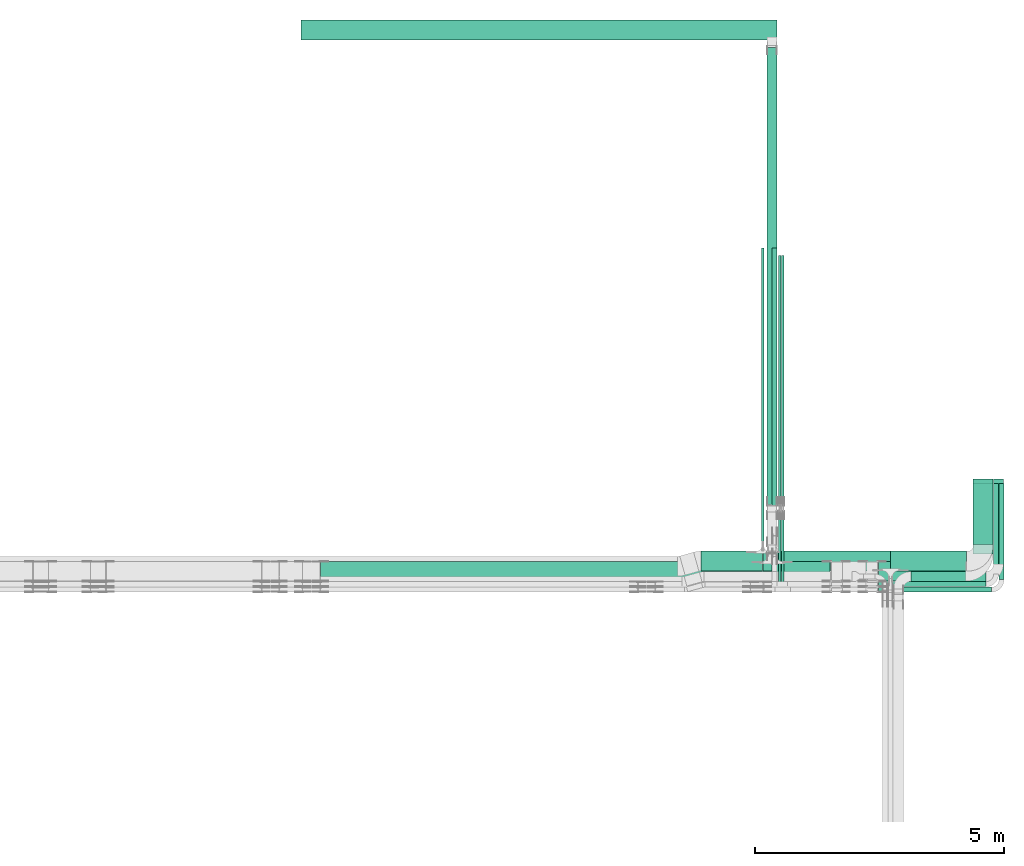
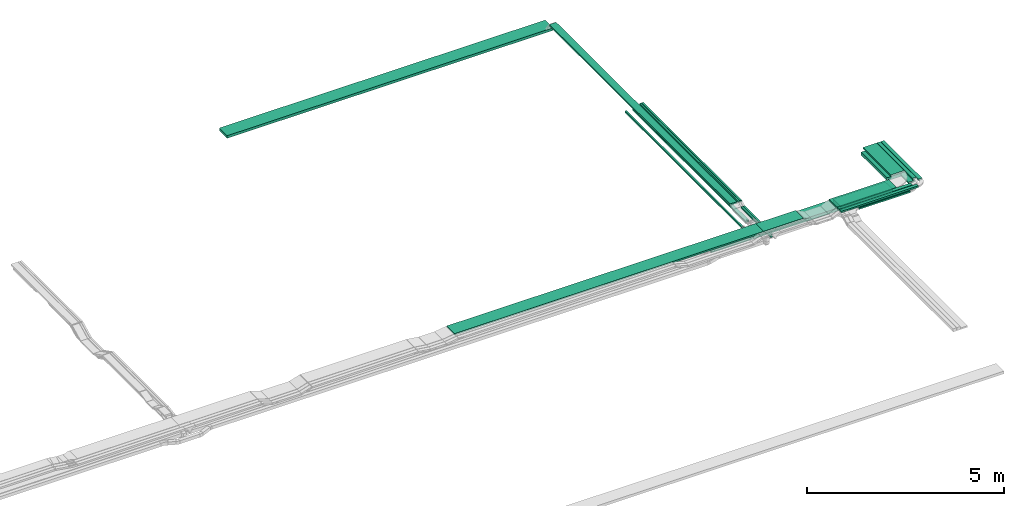
# One storey, part 3 of 28: 22 flow segments.
"""IFC2X3 building model written with IfcOpenShell, lengths in millimetres."""

from ifc_helpers import new_model, entity, si_unit, converted_unit, derived_unit, direction, frame, frame_2d, origin, origin_2d_with_axis, place, context, subcontext, project, spatial, rectangle, extrude, type_object, element, save


model = new_model("IFC2X3")

# Units and contexts
model_context = context("Model", 3, precision=0.01, world=origin(), true_north=direction((6.12303176911189e-17, 1.0)))
body_context = subcontext(model_context, "Body", "Model", "MODEL_VIEW")
ifc_project = project(units=[si_unit("LENGTHUNIT", "METRE", prefix="MILLI"), si_unit("AREAUNIT", "SQUARE_METRE"), si_unit("VOLUMEUNIT", "CUBIC_METRE"), converted_unit("PLANEANGLEUNIT", "DEGREE", entity("IfcRatioMeasure", 0.0174532925199433), si_unit("PLANEANGLEUNIT", "RADIAN"), dimensions=[0, 0, 0, 0, 0, 0, 0]), si_unit("MASSUNIT", "GRAM", prefix="KILO"), derived_unit("MASSDENSITYUNIT", [(si_unit("MASSUNIT", "GRAM", prefix="KILO"), 1), (si_unit("LENGTHUNIT", "METRE"), -3)]), derived_unit("MOMENTOFINERTIAUNIT", [(si_unit("LENGTHUNIT", "METRE"), 4)]), si_unit("TIMEUNIT", "SECOND"), si_unit("FREQUENCYUNIT", "HERTZ"), si_unit("THERMODYNAMICTEMPERATUREUNIT", "DEGREE_CELSIUS"), derived_unit("THERMALTRANSMITTANCEUNIT", [(si_unit("MASSUNIT", "GRAM", prefix="KILO"), 1), (si_unit("THERMODYNAMICTEMPERATUREUNIT", "KELVIN"), -1), (si_unit("TIMEUNIT", "SECOND"), -3)]), derived_unit("VOLUMETRICFLOWRATEUNIT", [(si_unit("LENGTHUNIT", "METRE"), 3), (si_unit("TIMEUNIT", "SECOND"), -1)]), derived_unit("MASSFLOWRATEUNIT", [(si_unit("MASSUNIT", "GRAM", prefix="KILO"), 1), (si_unit("TIMEUNIT", "SECOND"), -1)]), derived_unit("ROTATIONALFREQUENCYUNIT", [(si_unit("TIMEUNIT", "SECOND"), -1)]), si_unit("ELECTRICCURRENTUNIT", "AMPERE"), si_unit("ELECTRICVOLTAGEUNIT", "VOLT"), si_unit("POWERUNIT", "WATT"), si_unit("FORCEUNIT", "NEWTON", prefix="KILO"), si_unit("ILLUMINANCEUNIT", "LUX"), si_unit("LUMINOUSFLUXUNIT", "LUMEN"), si_unit("LUMINOUSINTENSITYUNIT", "CANDELA"), derived_unit("USERDEFINED", [(si_unit("MASSUNIT", "GRAM", prefix="KILO"), -1), (si_unit("LENGTHUNIT", "METRE"), -2), (si_unit("TIMEUNIT", "SECOND"), 3), (si_unit("LUMINOUSFLUXUNIT", "LUMEN"), 1)]), derived_unit("LINEARVELOCITYUNIT", [(si_unit("LENGTHUNIT", "METRE"), 1), (si_unit("TIMEUNIT", "SECOND"), -1)]), si_unit("PRESSUREUNIT", "PASCAL"), derived_unit("USERDEFINED", [(si_unit("LENGTHUNIT", "METRE"), -2), (si_unit("MASSUNIT", "GRAM", prefix="KILO"), 1), (si_unit("TIMEUNIT", "SECOND"), -2)]), derived_unit("LINEARFORCEUNIT", [(si_unit("MASSUNIT", "GRAM", prefix="KILO"), 1), (si_unit("LENGTHUNIT", "METRE"), 1), (si_unit("TIMEUNIT", "SECOND"), -2), (si_unit("LENGTHUNIT", "METRE"), -1)]), derived_unit("PLANARFORCEUNIT", [(si_unit("MASSUNIT", "GRAM", prefix="KILO"), 1), (si_unit("LENGTHUNIT", "METRE"), 1), (si_unit("TIMEUNIT", "SECOND"), -2), (si_unit("LENGTHUNIT", "METRE"), -2)])], contexts=[model_context])

# Site, building, storey
site_placement = place(None, frame((0.0, -0.00077364408347762, 0.0)))
site = spatial("IfcSite", under=ifc_project, at=site_placement, CompositionType="ELEMENT")
building_placement = place(site_placement, origin())
building = spatial("IfcBuilding", under=site, at=building_placement, CompositionType="ELEMENT")
storey_placement = place(building_placement, origin())
storey = spatial("IfcBuildingStorey", under=building, at=storey_placement, CompositionType="ELEMENT", Elevation=0.0)

# Flow segments
cable_carrier_segment_type = type_object("IfcCableCarrierSegmentType", PredefinedType="CABLETRAYSEGMENT")
flow_segment_1_placement = place(storey_placement, frame((64007.7697248974, 9444.27066099216, 2600.0)))
element("IfcFlowSegment", 1, at=flow_segment_1_placement, inside=storey, type_object=cable_carrier_segment_type, context=body_context, shape_type="SweptSolid", body=[
    extrude(rectangle(XDim=5768.12467532729, YDim=99.9999999999946, at=frame_2d((6.82121026329696e-13, 4.33075797445781e-12), x_axis=(1.0, 0.0))), frame((50.0, 2884.06233766365, 0.0), z_axis=(0.0, 0.0, 1.0), x_axis=(0.0, 1.0, 0.0)), (0.0, 0.0, 1.0), 49.9999999999995),
])
flow_segment_2_placement = place(storey_placement, frame((64197.1849606245, 10059.6497942623, 2800.0)))
element("IfcFlowSegment", 2, at=flow_segment_2_placement, inside=storey, type_object=cable_carrier_segment_type, context=body_context, shape_type="SweptSolid", body=[
    extrude(rectangle(XDim=5010.35026677283, YDim=50.000000000006, at=origin_2d_with_axis()), frame((25.0, 2505.17513338642, 0.0), z_axis=(0.0, 0.0, 1.0), x_axis=(0.0, 1.0, 0.0)), (0.0, 0.0, 1.0), 50.0000000000005),
])
flow_segment_3_placement = place(storey_placement, frame((64137.1849606246, 10059.6497942633, 2800.0)))
element("IfcFlowSegment", 3, at=flow_segment_3_placement, inside=storey, type_object=cable_carrier_segment_type, context=body_context, shape_type="SweptSolid", body=[
    extrude(rectangle(XDim=5010.3502667718, YDim=50.000000000006, at=frame_2d((-1.13686837721616e-12, 0.0), x_axis=(1.0, 0.0))), frame((25.0, 2505.1751333859, 0.0), z_axis=(0.0, 0.0, 1.0), x_axis=(0.0, 1.0, 0.0)), (0.0, 0.0, 1.0), 50.0000000000005),
])
flow_segment_4_placement = place(storey_placement, frame((63792.1849606245, 9272.39533631945, 2600.0)))
element("IfcFlowSegment", 4, at=flow_segment_4_placement, inside=storey, type_object=cable_carrier_segment_type, context=body_context, shape_type="SweptSolid", body=[
    extrude(rectangle(XDim=5940.0, YDim=50.000000000006, at=frame_2d((-1.13686837721616e-12, 0.0), x_axis=(1.0, 0.0))), frame((25.0, 2970.0, 0.0), z_axis=(0.0, 0.0, 1.0), x_axis=(0.0, -1.0, 0.0)), (0.0, 0.0, 1.0), 49.9999999999995),
])
flow_segment_5_placement = place(storey_placement, frame((68046.0094990459, 9254.3275570197, 2600.0)))
element("IfcFlowSegment", 5, at=flow_segment_5_placement, inside=storey, type_object=cable_carrier_segment_type, context=body_context, shape_type="SweptSolid", body=[
    extrude(rectangle(XDim=1317.94944193116, YDim=399.999999999996, at=frame_2d((1.08002495835535e-12, 0.0), x_axis=(1.0, 0.0))), frame((200.0, 658.974720965585, 0.0), z_axis=(0.0, 0.0, 1.0), x_axis=(0.0, -1.0, 0.0)), (0.0, 0.0, 1.0), 100.000000000001),
])
flow_segment_6_placement = place(storey_placement, frame((62577.106387771, 8724.32755701977, 2600.0)))
element("IfcFlowSegment", 6, at=flow_segment_6_placement, inside=storey, type_object=cable_carrier_segment_type, context=body_context, shape_type="SweptSolid", body=[
    extrude(rectangle(XDim=1239.07857285351, YDim=400.0, at=frame_2d((4.32009983342141e-12, 0.0), x_axis=(1.0, 0.0))), frame((619.539286426752, 200.0, 0.0)), (0.0, 0.0, 1.0), 100.0),
])
flow_segment_7_placement = place(storey_placement, frame((66385.9973266601, 8724.32755701969, 2600.0)))
element("IfcFlowSegment", 7, at=flow_segment_7_placement, inside=storey, type_object=cable_carrier_segment_type, context=body_context, shape_type="SweptSolid", body=[
    extrude(rectangle(XDim=1530.01217238575, YDim=400.0, at=frame_2d((-4.32009983342141e-12, 0.0), x_axis=(1.0, 0.0))), frame((765.006086192933, 200.0, 0.0), z_axis=(0.0, 0.0, 1.0), x_axis=(-1.0, 0.0, 0.0)), (0.0, 0.0, 1.0), 100.0),
])
flow_segment_8_placement = place(storey_placement, frame((66145.2562552068, 8520.00006103514, 2850.0)))
element("IfcFlowSegment", 8, at=flow_segment_8_placement, inside=storey, type_object=cable_carrier_segment_type, context=body_context, shape_type="SweptSolid", body=[
    extrude(rectangle(XDim=1749.75324383906, YDim=400.0, at=frame_2d((-4.32009983342141e-12, 0.0), x_axis=(1.0, 0.0))), frame((874.876621919528, 200.0, 0.0), z_axis=(0.0, 0.0, 1.0), x_axis=(-1.0, 0.0, 0.0)), (0.0, 0.0, 1.0), 49.9999999999995),
])
flow_segment_9_placement = place(storey_placement, frame((68046.0094990459, 9071.00006103515, 2850.0)))
element("IfcFlowSegment", 9, at=flow_segment_9_placement, inside=storey, type_object=cable_carrier_segment_type, context=body_context, shape_type="SweptSolid", body=[
    extrude(rectangle(XDim=1408.99999999999, YDim=399.999999999996, at=frame_2d((-1.13686837721616e-12, 0.0), x_axis=(1.0, 0.0))), frame((200.0, 704.499999999998, 0.0), z_axis=(0.0, 0.0, 1.0), x_axis=(0.0, 1.0, 0.0)), (0.0, 0.0, 1.0), 49.9999999999995),
])
flow_segment_10_placement = place(storey_placement, frame((66145.2562552068, 8410.0000610352, 2850.0)))
element("IfcFlowSegment", 10, at=flow_segment_10_placement, inside=storey, type_object=cable_carrier_segment_type, context=body_context, shape_type="SweptSolid", body=[
    extrude(rectangle(XDim=2159.75324383904, YDim=99.9999999999989, at=frame_2d((4.32009983342141e-12, 5.40012479177676e-13), x_axis=(1.0, 0.0))), frame((1079.87662191952, 50.0, 0.0), z_axis=(0.0, 0.0, 1.0), x_axis=(-1.0, 0.0, 0.0)), (0.0, 0.0, 1.0), 49.9999999999995),
])
flow_segment_11_placement = place(storey_placement, frame((68456.0094990459, 8661.00006103521, 2850.0)))
element("IfcFlowSegment", 11, at=flow_segment_11_placement, inside=storey, type_object=cable_carrier_segment_type, context=body_context, shape_type="SweptSolid", body=[
    extrude(rectangle(XDim=1818.99999999993, YDim=99.9999999999946, at=frame_2d((-5.11590769747272e-13, 4.33075797445781e-12), x_axis=(1.0, 0.0))), frame((50.0, 909.499999999962, 0.0), z_axis=(0.0, 0.0, 1.0), x_axis=(0.0, 1.0, 0.0)), (0.0, 0.0, 1.0), 49.9999999999995),
])
flow_segment_12_placement = place(storey_placement, frame((64197.1849606245, 8489.63636047901, 2719.28711978991)))
element("IfcFlowSegment", 12, at=flow_segment_12_placement, inside=storey, type_object=cable_carrier_segment_type, context=body_context, shape_type="SweptSolid", body=[
    extrude(rectangle(XDim=1417.59981973826, YDim=50.000000000006, at=origin_2d_with_axis()), frame((25.0, 708.79990986913, 0.0), z_axis=(0.0, 0.0, 1.0), x_axis=(0.0, -1.0, 0.0)), (0.0, 0.0, 1.0), 50.0000000000005),
])
flow_segment_13_placement = place(storey_placement, frame((64137.1849606246, 8409.32755701974, 2721.0)))
element("IfcFlowSegment", 13, at=flow_segment_13_placement, inside=storey, type_object=cable_carrier_segment_type, context=body_context, shape_type="SweptSolid", body=[
    extrude(rectangle(XDim=1500.75933458754, YDim=50.000000000006, at=frame_2d((0.0, 8.66329230575502e-12), x_axis=(1.0, 0.0))), frame((25.0, 750.379667293769, 0.0), z_axis=(0.0, 0.0, 1.0), x_axis=(0.0, 1.0, 0.0)), (0.0, 0.0, 1.0), 50.0000000000005),
])
flow_segment_14_placement = place(storey_placement, frame((66145.2562552068, 8300.00006103515, 2850.0)))
element("IfcFlowSegment", 14, at=flow_segment_14_placement, inside=storey, type_object=cable_carrier_segment_type, context=body_context, shape_type="SweptSolid", body=[
    extrude(rectangle(XDim=2269.75324383909, YDim=99.9999999999989, at=frame_2d((0.0, -5.40012479177676e-13), x_axis=(1.0, 0.0))), frame((1134.87662191955, 50.0, 0.0), z_axis=(0.0, 0.0, 1.0), x_axis=(-1.0, 0.0, 0.0)), (0.0, 0.0, 1.0), 49.9999999999995),
])
flow_segment_15_placement = place(storey_placement, frame((68566.0094990458, 8551.00006103517, 2850.0)))
element("IfcFlowSegment", 15, at=flow_segment_15_placement, inside=storey, type_object=cable_carrier_segment_type, context=body_context, shape_type="SweptSolid", body=[
    extrude(rectangle(XDim=1928.99999999997, YDim=99.9999999999946, at=frame_2d((-5.6843418860808e-13, -4.33075797445781e-12), x_axis=(1.0, 0.0))), frame((50.0, 964.499999999984, 0.0), z_axis=(0.0, 0.0, 1.0), x_axis=(0.0, 1.0, 0.0)), (0.0, 0.0, 1.0), 49.9999999999995),
])
flow_segment_16_placement = place(storey_placement, frame((63818.1849606245, 8724.32755701973, 2600.0)))
element("IfcFlowSegment", 16, at=flow_segment_16_placement, inside=storey, type_object=cable_carrier_segment_type, context=body_context, shape_type="SweptSolid", body=[
    extrude(rectangle(XDim=2565.81236603563, YDim=400.0, at=frame_2d((4.32009983342141e-12, 0.0), x_axis=(1.0, 0.0))), frame((1282.90618301781, 200.0, 0.0)), (0.0, 0.0, 1.0), 100.0),
])
flow_segment_17_placement = place(storey_placement, frame((68456.0094990459, 8865.3275570197, 2600.0)))
element("IfcFlowSegment", 17, at=flow_segment_17_placement, inside=storey, type_object=cable_carrier_segment_type, context=body_context, shape_type="SweptSolid", body=[
    extrude(rectangle(XDim=1706.94944193117, YDim=200.000000000007, at=frame_2d((-5.11590769747272e-13, 4.33431068813661e-12), x_axis=(1.0, 0.0))), frame((100.0, 853.474720965584, 0.0), z_axis=(0.0, 0.0, 1.0), x_axis=(0.0, -1.0, 0.0)), (0.0, 0.0, 1.0), 49.9999999999995),
])
flow_segment_18_placement = place(storey_placement, frame((66795.9973266601, 8514.32755701969, 2600.0)))
element("IfcFlowSegment", 18, at=flow_segment_18_placement, inside=storey, type_object=cable_carrier_segment_type, context=body_context, shape_type="SweptSolid", body=[
    extrude(rectangle(XDim=1509.01217238576, YDim=200.0, at=frame_2d((-4.32009983342141e-12, 0.0), x_axis=(1.0, 0.0))), frame((754.506086192875, 100.0, 0.0), z_axis=(0.0, 0.0, 1.0), x_axis=(-1.0, 0.0, 0.0)), (0.0, 0.0, 1.0), 50.0000000000005),
])
flow_segment_19_placement = place(storey_placement, frame((54929.7964531974, 8520.00006103515, 2850.0)))
element("IfcFlowSegment", 19, at=flow_segment_19_placement, inside=storey, type_object=cable_carrier_segment_type, context=body_context, shape_type="SweptSolid", body=[
    extrude(rectangle(XDim=9071.38850742713, YDim=400.0, at=frame_2d((0.0, 5.54223333892878e-13), x_axis=(1.0, 0.0))), frame((4535.69425371357, 200.0, 0.0), z_axis=(0.0, 0.0, 1.0), x_axis=(-1.0, 0.0, 0.0)), (0.0, 0.0, 1.0), 49.9999999999995),
])
flow_segment_20_placement = place(storey_placement, frame((64003.1849606245, 8520.00006103515, 2850.0)))
element("IfcFlowSegment", 20, at=flow_segment_20_placement, inside=storey, type_object=cable_carrier_segment_type, context=body_context, shape_type="SweptSolid", body=[
    extrude(rectangle(XDim=1167.15792122105, YDim=400.0, at=frame_2d((0.0, -5.54223333892878e-13), x_axis=(1.0, 0.0))), frame((583.578960610526, 200.0, 0.0)), (0.0, 0.0, 1.0), 49.9999999999995),
])
flow_segment_21_placement = place(storey_placement, frame((54539.0605119568, 19400.0026718375, 2500.0)))
element("IfcFlowSegment", 21, at=flow_segment_21_placement, inside=storey, type_object=cable_carrier_segment_type, context=body_context, shape_type="SweptSolid", body=[
    extrude(rectangle(XDim=9563.12444866768, YDim=400.000000000002, at=frame_2d((4.54747350886464e-12, -1.09423581307055e-12), x_axis=(1.0, 0.0))), frame((4781.56222433384, 200.0, 0.0), z_axis=(0.0, 0.0, 1.0), x_axis=(-1.0, 0.0, 0.0)), (0.0, 0.0, 1.0), 80.0000000000002),
])
flow_segment_22_placement = place(storey_placement, frame((63902.1849606245, 10059.6497942667, 2800.0)))
element("IfcFlowSegment", 22, at=flow_segment_22_placement, inside=storey, type_object=cable_carrier_segment_type, context=body_context, shape_type="SweptSolid", body=[
    extrude(rectangle(XDim=9184.86114375628, YDim=200.000000000007, at=frame_2d((2.27373675443232e-12, 0.0), x_axis=(1.0, 0.0))), frame((100.0, 4592.43057187814, 0.0), z_axis=(0.0, 0.0, 1.0), x_axis=(0.0, 1.0, 0.0)), (0.0, 0.0, 1.0), 50.0000000000005),
])

save(model, "model.ifc")
